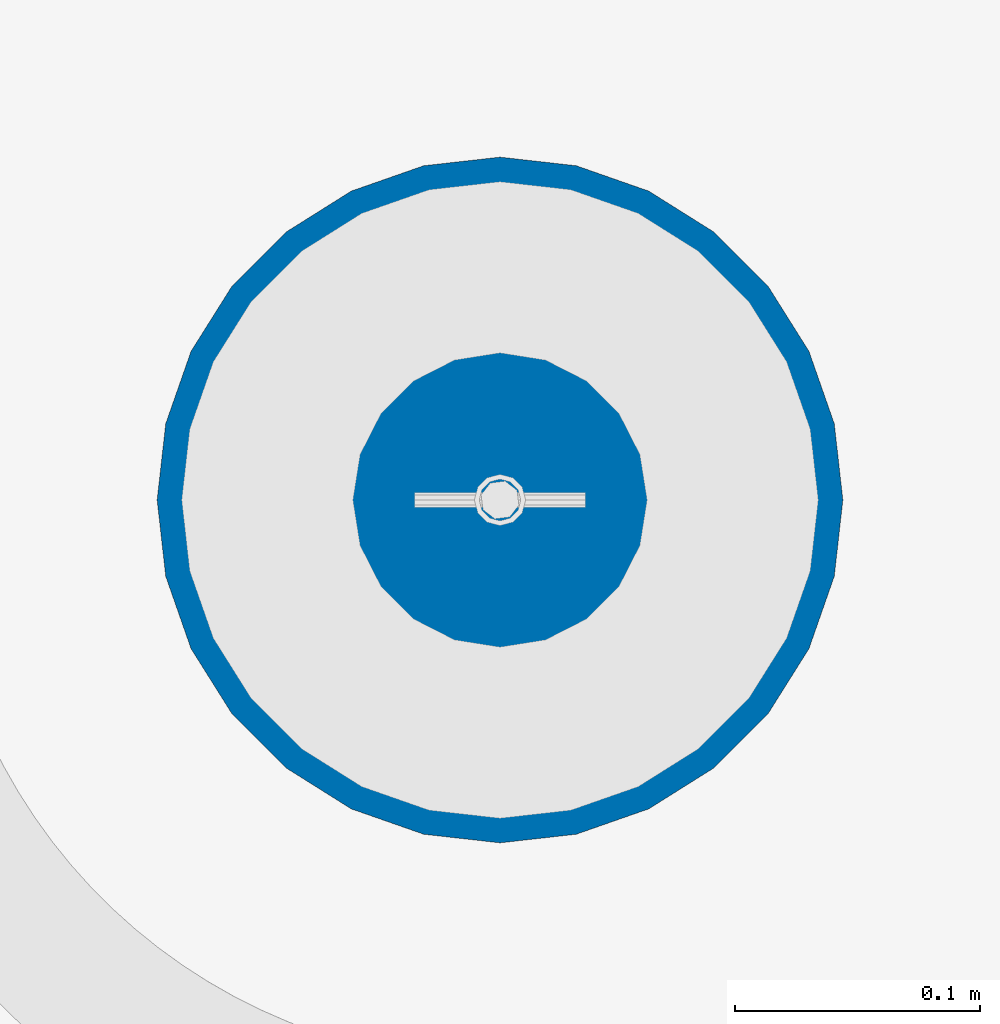
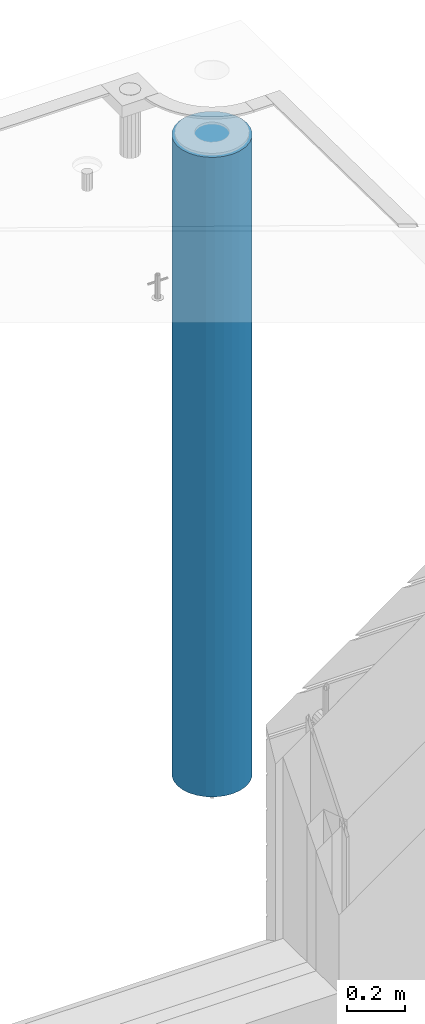
# One storey, part 7 of 349: 1 column, 1 element without a shape of its own.
"""IFC2X3 building model written with IfcOpenShell, lengths in millimetres."""

from ifc_helpers import new_model, si_unit, frame, origin_with_axes, place, context, subcontext, project, spatial, faceted_brep, material, type_object, element, aggregate, save


model = new_model("IFC2X3")

# Units and contexts
model_context = context("Model", 3, precision=1e-05, world=origin_with_axes())
body_context = subcontext(model_context, "Body", "Model", "MODEL_VIEW")
ifc_project = project(units=[si_unit("LENGTHUNIT", "METRE", prefix="MILLI"), si_unit("AREAUNIT", "SQUARE_METRE"), si_unit("VOLUMEUNIT", "CUBIC_METRE"), si_unit("MASSUNIT", "GRAM", prefix="KILO"), si_unit("TIMEUNIT", "SECOND"), si_unit("PLANEANGLEUNIT", "RADIAN"), si_unit("SOLIDANGLEUNIT", "STERADIAN"), si_unit("THERMODYNAMICTEMPERATUREUNIT", "DEGREE_CELSIUS"), si_unit("LUMINOUSINTENSITYUNIT", "LUMEN")], contexts=[model_context])

# Site, building, storey
site_placement = place(None, origin_with_axes())
site = spatial("IfcSite", under=ifc_project, at=site_placement, CompositionType="ELEMENT")
building_placement = place(site_placement, origin_with_axes())
building = spatial("IfcBuilding", under=site, at=building_placement, CompositionType="ELEMENT")
storey_placement = place(building_placement, origin_with_axes())
storey = spatial("IfcBuildingStorey", under=building, at=storey_placement, Name="4", CompositionType="ELEMENT", Elevation=0.0)

# Assembly, column
assembly_placement = place(storey_placement, origin_with_axes())
assembly = element("IfcElementAssembly", 1, at=assembly_placement, inside=storey, AssemblyPlace="NOTDEFINED", PredefinedType="REINFORCEMENT_UNIT")
ifc_material = material(Name="CONCRETE/C30/37")
column_type = type_object("IfcColumnType", Name="D280", PredefinedType="NOTDEFINED")
column_placement = place(assembly_placement, frame((35009.9987952044, 22669.984888838, 90725.0), z_axis=(-1.0, 3.00000001838171e-08, 0.0), x_axis=(0.0, 0.0, 1.0)))
column = element("IfcColumn", 2, at=column_placement, type_object=column_type, material=ifc_material, ObjectType="D280", context=body_context, shape_type="Brep", body=[
    faceted_brep([(0.0, -140.0, 0.0), (0.0, -136.489907705454, -31.1529307538876), (2710.0, -136.489907705454, -31.1529307538876), (2710.0, -140.0, 0.0), (0.0, -126.135641506338, -60.7437234764584), (2710.0, -126.135641506338, -60.7437234764584), (0.0, -109.456407545524, -87.2885722602223), (2710.0, -109.456407545524, -87.2885722602223), (0.0, -87.2885722602223, -109.456407545527), (2710.0, -87.2885722602223, -109.456407545527), (0.0, -60.7437234764584, -126.135641506342), (2710.0, -60.7437234764584, -126.135641506342), (0.0, -31.152930753884, -136.489907705458), (2710.0, -31.152930753884, -136.489907705458), (0.0, 0.0, -140.0), (2710.0, 0.0, -140.0), (0.0, 31.152930753884, -136.489907705458), (2710.0, 31.152930753884, -136.489907705458), (0.0, 60.7437234764584, -126.135641506342), (2710.0, 60.7437234764584, -126.135641506342), (0.0, 87.2885722602223, -109.456407545527), (2710.0, 87.2885722602223, -109.456407545527), (0.0, 109.456407545524, -87.2885722602223), (2710.0, 109.456407545524, -87.2885722602223), (0.0, 126.135641506338, -60.7437234764584), (2710.0, 126.135641506338, -60.7437234764584), (0.0, 136.489907705454, -31.1529307538876), (2710.0, 136.489907705454, -31.1529307538876), (0.0, 140.0, 0.0), (2710.0, 140.0, 0.0), (0.0, 136.489907705454, 31.1529307538876), (2710.0, 136.489907705454, 31.1529307538876), (0.0, 126.135641506338, 60.7437234764584), (2710.0, 126.135641506338, 60.7437234764584), (0.0, 109.456407545524, 87.2885722602223), (2710.0, 109.456407545524, 87.2885722602223), (0.0, 87.2885722602223, 109.456407545527), (2710.0, 87.2885722602223, 109.456407545527), (0.0, 60.7437234764584, 126.135641506342), (2710.0, 60.7437234764584, 126.135641506342), (0.0, 31.152930753884, 136.489907705458), (2710.0, 31.152930753884, 136.489907705458), (0.0, 0.0, 140.0), (2710.0, 0.0, 140.0), (0.0, -31.152930753884, 136.489907705458), (2710.0, -31.152930753884, 136.489907705458), (0.0, -60.7437234764584, 126.135641506342), (2710.0, -60.7437234764584, 126.135641506342), (0.0, -87.2885722602223, 109.456407545527), (2710.0, -87.2885722602223, 109.456407545527), (0.0, -109.456407545524, 87.2885722602223), (2710.0, -109.456407545524, 87.2885722602223), (0.0, -126.135641506338, 60.7437234764584), (2710.0, -126.135641506338, 60.7437234764584), (0.0, -136.489907705454, 31.1529307538876), (2710.0, -136.489907705454, 31.1529307538876)], [[[0, 1, 2, 3]], [[1, 4, 5, 2]], [[4, 6, 7, 5]], [[6, 8, 9, 7]], [[8, 10, 11, 9]], [[10, 12, 13, 11]], [[12, 14, 15, 13]], [[14, 16, 17, 15]], [[16, 18, 19, 17]], [[18, 20, 21, 19]], [[20, 22, 23, 21]], [[22, 24, 25, 23]], [[24, 26, 27, 25]], [[26, 28, 29, 27]], [[28, 30, 31, 29]], [[30, 32, 33, 31]], [[32, 34, 35, 33]], [[34, 36, 37, 35]], [[36, 38, 39, 37]], [[38, 40, 41, 39]], [[40, 42, 43, 41]], [[42, 44, 45, 43]], [[44, 46, 47, 45]], [[46, 48, 49, 47]], [[48, 50, 51, 49]], [[50, 52, 53, 51]], [[52, 54, 55, 53]], [[54, 0, 3, 55]], [[5, 7, 9, 11, 13, 15, 17, 19, 21, 23, 25, 27, 29, 31, 33, 35, 37, 39, 41, 43, 45, 47, 49, 51, 53, 55, 3, 2]], [[54, 52, 50, 48, 46, 44, 42, 40, 38, 36, 34, 32, 30, 28, 26, 24, 22, 20, 18, 16, 14, 12, 10, 8, 6, 4, 1, 0]]]),
])
aggregate(assembly, [column])

save(model, "model.ifc")
